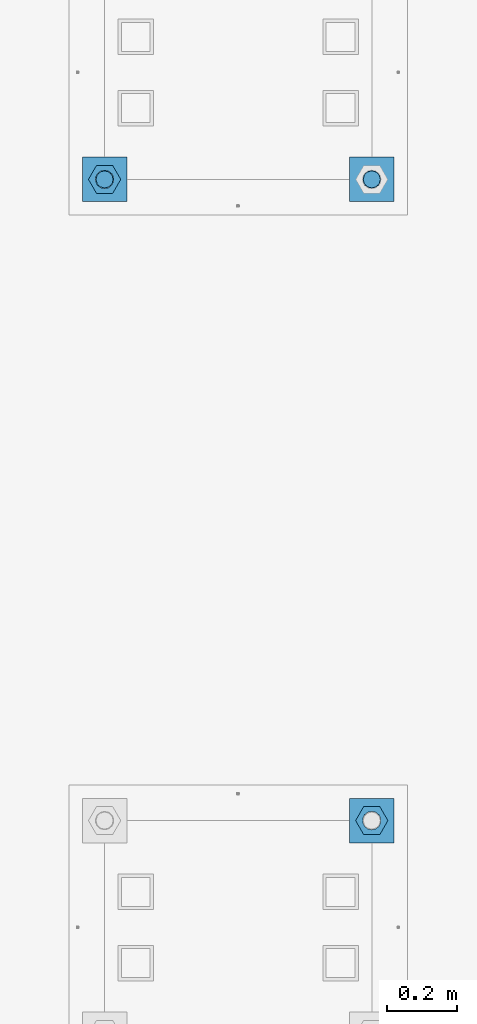
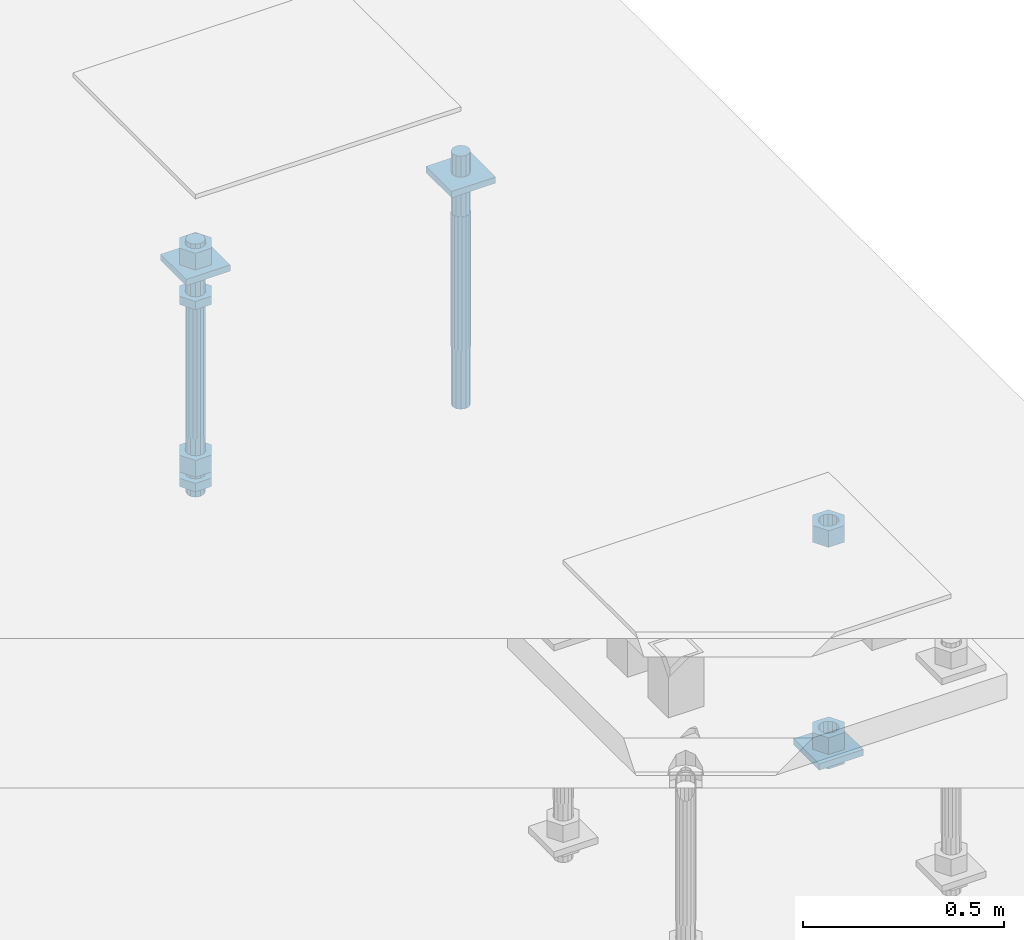
# One storey, part 2740 of 3843: 12 beams, 2 elements without a shape of their own.
"""IFC2X3 building model written with IfcOpenShell, lengths in millimetres."""

from ifc_helpers import new_model, si_unit, frame, origin_with_axes, place, context, subcontext, project, spatial, faceted_brep, material, type_object, element, aggregate, save


model = new_model("IFC2X3")

# Units and contexts
model_context = context("Model", 3, precision=1e-05, world=origin_with_axes())
body_context = subcontext(model_context, "Body", "Model", "MODEL_VIEW")
ifc_project = project(units=[si_unit("LENGTHUNIT", "METRE", prefix="MILLI"), si_unit("AREAUNIT", "SQUARE_METRE"), si_unit("VOLUMEUNIT", "CUBIC_METRE"), si_unit("MASSUNIT", "GRAM", prefix="KILO"), si_unit("TIMEUNIT", "SECOND"), si_unit("PLANEANGLEUNIT", "RADIAN"), si_unit("SOLIDANGLEUNIT", "STERADIAN"), si_unit("THERMODYNAMICTEMPERATUREUNIT", "DEGREE_CELSIUS"), si_unit("LUMINOUSINTENSITYUNIT", "LUMEN")], contexts=[model_context])

# Site, building, storey
site_placement = place(None, origin_with_axes())
site = spatial("IfcSite", under=ifc_project, at=site_placement, CompositionType="ELEMENT")
building_placement = place(site_placement, origin_with_axes())
building = spatial("IfcBuilding", under=site, at=building_placement, Name="Undefined", CompositionType="ELEMENT")
storey_placement = place(building_placement, origin_with_axes())
storey = spatial("IfcBuildingStorey", under=building, at=storey_placement, Name="Undefined", CompositionType="ELEMENT", Elevation=0.0)

# Assembly, beams
assembly_1_placement = place(storey_placement, origin_with_axes())
assembly_1 = element("IfcElementAssembly", 1, at=assembly_1_placement, inside=storey, Name="TEMPLATE", AssemblyPlace="NOTDEFINED", PredefinedType="RIGID_FRAME")
ifc_material_1 = material(Name="STEEL/A572-50")
beam_type_1 = type_object("IfcBeamType", PredefinedType="NOTDEFINED")
beam_1_placement = place(assembly_1_placement, frame((118465.6, 38188.9000015259, 29873.575), z_axis=(1.0, 0.0, 0.0), x_axis=(0.0, 1.0, 0.0)))
beam_1 = element("IfcBeam", 2, at=beam_1_placement, type_object=beam_type_1, material=ifc_material_1, Name="WASHER_PLATE", context=body_context, shape_type="Brep", body=[
    faceted_brep([(0.0, 9.52500000000146, -63.5), (0.0, 9.52500000000146, 63.5), (127.0, 9.52500000000146, 63.5), (127.0, 9.52500000000146, -63.5), (0.0, -9.52500000000146, 63.5), (127.0, -9.52500000000146, 63.5), (0.0, -9.52500000000146, -63.5), (127.0, -9.52500000000146, -63.5)], [[[0, 1, 2, 3]], [[1, 4, 5, 2]], [[4, 6, 7, 5]], [[6, 0, 3, 7]], [[5, 7, 3, 2]], [[6, 4, 1, 0]]]),
])
beam_2_placement = place(assembly_1_placement, frame((119227.6, 38188.9000015259, 29873.575), z_axis=(1.0, 0.0, 0.0), x_axis=(0.0, 1.0, 0.0)))
beam_2 = element("IfcBeam", 3, at=beam_2_placement, type_object=beam_type_1, material=ifc_material_1, Name="WASHER_PLATE", context=body_context, shape_type="Brep", body=[
    faceted_brep([(0.0, 9.52500000000146, -63.5), (0.0, 9.52500000000146, 63.5), (127.0, 9.52500000000146, 63.5), (127.0, 9.52500000000146, -63.5), (0.0, -9.52500000000146, 63.5), (127.0, -9.52500000000146, 63.5), (0.0, -9.52500000000146, -63.5), (127.0, -9.52500000000146, -63.5)], [[[0, 1, 2, 3]], [[1, 4, 5, 2]], [[4, 6, 7, 5]], [[6, 0, 3, 7]], [[5, 7, 3, 2]], [[6, 4, 1, 0]]]),
])

# Assembly, beam
assembly_2_placement = place(storey_placement, origin_with_axes())
assembly_2 = element("IfcElementAssembly", 4, at=assembly_2_placement, inside=storey, Name="TEMPLATE", AssemblyPlace="NOTDEFINED", PredefinedType="RIGID_FRAME")
beam_3_placement = place(assembly_2_placement, frame((119227.6, 36360.1000015259, 29244.925), z_axis=(1.0, 0.0, 0.0), x_axis=(0.0, 1.0, 0.0)))
beam_3 = element("IfcBeam", 5, at=beam_3_placement, type_object=beam_type_1, material=ifc_material_1, Name="WASHER_PLATE", context=body_context, shape_type="Brep", body=[
    faceted_brep([(0.0, 9.52500000000146, -63.5), (0.0, 9.52500000000146, 63.5), (127.0, 9.52500000000146, 63.5), (127.0, 9.52500000000146, -63.5), (0.0, -9.52500000000146, 63.5), (127.0, -9.52500000000146, 63.5), (0.0, -9.52500000000146, -63.5), (127.0, -9.52500000000146, -63.5)], [[[0, 1, 2, 3]], [[1, 4, 5, 2]], [[4, 6, 7, 5]], [[6, 0, 3, 7]], [[5, 7, 3, 2]], [[6, 4, 1, 0]]]),
])

# Beam
ifc_material_2 = material(Name="STEEL/A36")
beam_type_2 = type_object("IfcBeamType", Name="2_HALF_NUT", PredefinedType="NOTDEFINED")
beam_4_placement = place(assembly_1_placement, frame((118465.6, 38252.4000015259, 29787.85), z_axis=(0.0, 1.0, 0.0), x_axis=(0.0, 0.0, -1.0)))
beam_4 = element("IfcBeam", 6, at=beam_4_placement, type_object=beam_type_2, material=ifc_material_2, Name="NUT", ObjectType="2_HALF_NUT", context=body_context, shape_type="Brep", body=[
    faceted_brep([(0.0, -46.0369987487793, 0.0), (0.0, -23.0184993743896, -39.869213104248), (25.4000000000015, -23.0184993743896, -39.869213104248), (25.4000000000015, -46.0369987487793, 0.0), (0.0, 23.0184993743896, -39.869213104248), (25.4000000000015, 23.0184993743896, -39.869213104248), (0.0, 46.0369987487793, 0.0), (25.4000000000015, 46.0369987487793, 0.0), (0.0, 23.0184993743896, 39.869213104248), (25.4000000000015, 23.0184993743896, 39.869213104248), (0.0, -23.0184993743896, 39.869213104248), (25.4000000000015, -23.0184993743896, 39.869213104248), (0.0, 0.0, 26.1940002441406), (0.0, 11.3650617044477, 23.5999013092805), (25.4000000000015, 11.3650617044477, 23.5999013092805), (25.4000000000015, 0.0, 26.1940002441406), (0.0, 20.4791109456419, 16.3316083006721), (25.4000000000015, 20.4791109456419, 16.3316083006721), (0.0, 25.5370200498292, 5.82867859874386), (25.4000000000015, 25.5370200498292, 5.82867859874386), (0.0, 25.5370200498292, -5.82867859874386), (25.4000000000015, 25.5370200498292, -5.82867859874386), (0.0, 20.4791109456419, -16.3316083006721), (25.4000000000015, 20.4791109456419, -16.3316083006721), (0.0, 11.3650617044477, -23.5999013092805), (25.4000000000015, 11.3650617044477, -23.5999013092805), (0.0, 0.0, -26.1940002441406), (25.4000000000015, 0.0, -26.1940002441406), (0.0, -11.3650617044477, -23.5999013092805), (25.4000000000015, -11.3650617044477, -23.5999013092805), (0.0, -20.4791109456419, -16.3316083006721), (25.4000000000015, -20.4791109456419, -16.3316083006721), (0.0, -25.5370200498292, -5.82867859874386), (25.4000000000015, -25.5370200498292, -5.82867859874386), (0.0, -25.5370200498292, 5.82867859874386), (25.4000000000015, -25.5370200498292, 5.82867859874386), (0.0, -20.4791109456419, 16.3316083006721), (25.4000000000015, -20.4791109456419, 16.3316083006721), (0.0, -11.3650617044477, 23.5999013092805), (25.4000000000015, -11.3650617044477, 23.5999013092805)], [[[0, 1, 2, 3]], [[1, 4, 5, 2]], [[4, 6, 7, 5]], [[6, 8, 9, 7]], [[8, 10, 11, 9]], [[10, 0, 3, 11]], [[12, 13, 14, 15]], [[13, 16, 17, 14]], [[16, 18, 19, 17]], [[18, 20, 21, 19]], [[20, 22, 23, 21]], [[22, 24, 25, 23]], [[24, 26, 27, 25]], [[26, 28, 29, 27]], [[28, 30, 31, 29]], [[30, 32, 33, 31]], [[32, 34, 35, 33]], [[34, 36, 37, 35]], [[36, 38, 39, 37]], [[38, 12, 15, 39]], [[5, 7, 9, 11, 3, 2], [17, 19, 21, 23, 25, 27, 29, 31, 33, 35, 37, 39, 15, 14]], [[10, 8, 6, 4, 1, 0], [38, 36, 34, 32, 30, 28, 26, 24, 22, 20, 18, 16, 13, 12]]]),
])

beam_5_placement = place(assembly_1_placement, frame((118465.6, 38252.4000015259, 29235.4), z_axis=(0.0, 1.0, 0.0), x_axis=(0.0, 0.0, -1.0)))
beam_5 = element("IfcBeam", 7, at=beam_5_placement, type_object=beam_type_2, material=ifc_material_2, Name="NUT", ObjectType="2_HALF_NUT", context=body_context, shape_type="Brep", body=[
    faceted_brep([(0.0, -46.0369987487793, 0.0), (0.0, -23.0184993743896, -39.869213104248), (25.4000000000015, -23.0184993743896, -39.869213104248), (25.4000000000015, -46.0369987487793, 0.0), (0.0, 23.0184993743896, -39.869213104248), (25.4000000000015, 23.0184993743896, -39.869213104248), (0.0, 46.0369987487793, 0.0), (25.4000000000015, 46.0369987487793, 0.0), (0.0, 23.0184993743896, 39.869213104248), (25.4000000000015, 23.0184993743896, 39.869213104248), (0.0, -23.0184993743896, 39.869213104248), (25.4000000000015, -23.0184993743896, 39.869213104248), (0.0, 0.0, 26.1940002441406), (0.0, 11.3650617044477, 23.5999013092805), (25.4000000000015, 11.3650617044477, 23.5999013092805), (25.4000000000015, 0.0, 26.1940002441406), (0.0, 20.4791109456419, 16.3316083006721), (25.4000000000015, 20.4791109456419, 16.3316083006721), (0.0, 25.5370200498292, 5.82867859874386), (25.4000000000015, 25.5370200498292, 5.82867859874386), (0.0, 25.5370200498292, -5.82867859874386), (25.4000000000015, 25.5370200498292, -5.82867859874386), (0.0, 20.4791109456419, -16.3316083006721), (25.4000000000015, 20.4791109456419, -16.3316083006721), (0.0, 11.3650617044477, -23.5999013092805), (25.4000000000015, 11.3650617044477, -23.5999013092805), (0.0, 0.0, -26.1940002441406), (25.4000000000015, 0.0, -26.1940002441406), (0.0, -11.3650617044477, -23.5999013092805), (25.4000000000015, -11.3650617044477, -23.5999013092805), (0.0, -20.4791109456419, -16.3316083006721), (25.4000000000015, -20.4791109456419, -16.3316083006721), (0.0, -25.5370200498292, -5.82867859874386), (25.4000000000015, -25.5370200498292, -5.82867859874386), (0.0, -25.5370200498292, 5.82867859874386), (25.4000000000015, -25.5370200498292, 5.82867859874386), (0.0, -20.4791109456419, 16.3316083006721), (25.4000000000015, -20.4791109456419, 16.3316083006721), (0.0, -11.3650617044477, 23.5999013092805), (25.4000000000015, -11.3650617044477, 23.5999013092805)], [[[0, 1, 2, 3]], [[1, 4, 5, 2]], [[4, 6, 7, 5]], [[6, 8, 9, 7]], [[8, 10, 11, 9]], [[10, 0, 3, 11]], [[12, 13, 14, 15]], [[13, 16, 17, 14]], [[16, 18, 19, 17]], [[18, 20, 21, 19]], [[20, 22, 23, 21]], [[22, 24, 25, 23]], [[24, 26, 27, 25]], [[26, 28, 29, 27]], [[28, 30, 31, 29]], [[30, 32, 33, 31]], [[32, 34, 35, 33]], [[34, 36, 37, 35]], [[36, 38, 39, 37]], [[38, 12, 15, 39]], [[5, 7, 9, 11, 3, 2], [17, 19, 21, 23, 25, 27, 29, 31, 33, 35, 37, 39, 15, 14]], [[10, 8, 6, 4, 1, 0], [38, 36, 34, 32, 30, 28, 26, 24, 22, 20, 18, 16, 13, 12]]]),
])

beam_6_placement = place(assembly_2_placement, frame((119227.6, 36423.6000015259, 29235.4), z_axis=(0.0, 1.0, 0.0), x_axis=(0.0, 0.0, -1.0)))
beam_6 = element("IfcBeam", 8, at=beam_6_placement, type_object=beam_type_2, material=ifc_material_2, Name="NUT", ObjectType="2_HALF_NUT", context=body_context, shape_type="Brep", body=[
    faceted_brep([(0.0, -46.0369987487793, 0.0), (0.0, -23.0184993743896, -39.869213104248), (25.4000000000015, -23.0184993743896, -39.869213104248), (25.4000000000015, -46.0369987487793, 0.0), (0.0, 23.0184993743896, -39.869213104248), (25.4000000000015, 23.0184993743896, -39.869213104248), (0.0, 46.0369987487793, 0.0), (25.4000000000015, 46.0369987487793, 0.0), (0.0, 23.0184993743896, 39.869213104248), (25.4000000000015, 23.0184993743896, 39.869213104248), (0.0, -23.0184993743896, 39.869213104248), (25.4000000000015, -23.0184993743896, 39.869213104248), (0.0, 0.0, 26.1940002441406), (0.0, 11.3650617044477, 23.5999013092805), (25.4000000000015, 11.3650617044477, 23.5999013092805), (25.4000000000015, 0.0, 26.1940002441406), (0.0, 20.4791109456419, 16.3316083006721), (25.4000000000015, 20.4791109456419, 16.3316083006721), (0.0, 25.5370200498292, 5.82867859874386), (25.4000000000015, 25.5370200498292, 5.82867859874386), (0.0, 25.5370200498292, -5.82867859874386), (25.4000000000015, 25.5370200498292, -5.82867859874386), (0.0, 20.4791109456419, -16.3316083006721), (25.4000000000015, 20.4791109456419, -16.3316083006721), (0.0, 11.3650617044477, -23.5999013092805), (25.4000000000015, 11.3650617044477, -23.5999013092805), (0.0, 0.0, -26.1940002441406), (25.4000000000015, 0.0, -26.1940002441406), (0.0, -11.3650617044477, -23.5999013092805), (25.4000000000015, -11.3650617044477, -23.5999013092805), (0.0, -20.4791109456419, -16.3316083006721), (25.4000000000015, -20.4791109456419, -16.3316083006721), (0.0, -25.5370200498292, -5.82867859874386), (25.4000000000015, -25.5370200498292, -5.82867859874386), (0.0, -25.5370200498292, 5.82867859874386), (25.4000000000015, -25.5370200498292, 5.82867859874386), (0.0, -20.4791109456419, 16.3316083006721), (25.4000000000015, -20.4791109456419, 16.3316083006721), (0.0, -11.3650617044477, 23.5999013092805), (25.4000000000015, -11.3650617044477, 23.5999013092805)], [[[0, 1, 2, 3]], [[1, 4, 5, 2]], [[4, 6, 7, 5]], [[6, 8, 9, 7]], [[8, 10, 11, 9]], [[10, 0, 3, 11]], [[12, 13, 14, 15]], [[13, 16, 17, 14]], [[16, 18, 19, 17]], [[18, 20, 21, 19]], [[20, 22, 23, 21]], [[22, 24, 25, 23]], [[24, 26, 27, 25]], [[26, 28, 29, 27]], [[28, 30, 31, 29]], [[30, 32, 33, 31]], [[32, 34, 35, 33]], [[34, 36, 37, 35]], [[36, 38, 39, 37]], [[38, 12, 15, 39]], [[5, 7, 9, 11, 3, 2], [17, 19, 21, 23, 25, 27, 29, 31, 33, 35, 37, 39, 15, 14]], [[10, 8, 6, 4, 1, 0], [38, 36, 34, 32, 30, 28, 26, 24, 22, 20, 18, 16, 13, 12]]]),
])

beam_type_3 = type_object("IfcBeamType", Name="2_HEAVY_HEX_NUT", PredefinedType="NOTDEFINED")
beam_7_placement = place(assembly_1_placement, frame((118465.6, 38252.4000015259, 29933.9), z_axis=(0.0, 1.0, 0.0), x_axis=(0.0, 0.0, -1.0)))
beam_7 = element("IfcBeam", 9, at=beam_7_placement, type_object=beam_type_3, material=ifc_material_2, Name="NUT", ObjectType="2_HEAVY_HEX_NUT", context=body_context, shape_type="Brep", body=[
    faceted_brep([(0.0, -46.0369987487793, 0.0), (0.0, -23.0184993743896, -39.869213104248), (50.7999999999993, -23.0184993743896, -39.869213104248), (50.7999999999993, -46.0369987487793, 0.0), (0.0, 23.0184993743896, -39.869213104248), (50.7999999999993, 23.0184993743896, -39.869213104248), (0.0, 46.0369987487793, 0.0), (50.7999999999993, 46.0369987487793, 0.0), (0.0, 23.0184993743896, 39.869213104248), (50.7999999999993, 23.0184993743896, 39.869213104248), (0.0, -23.0184993743896, 39.869213104248), (50.7999999999993, -23.0184993743896, 39.869213104248), (0.0, 0.0, 26.1940002441406), (0.0, 11.3650617044477, 23.5999013092805), (50.7999999999993, 11.3650617044477, 23.5999013092805), (50.7999999999993, 0.0, 26.1940002441406), (0.0, 20.4791109456419, 16.3316083006721), (50.7999999999993, 20.4791109456419, 16.3316083006721), (0.0, 25.5370200498292, 5.82867859874386), (50.7999999999993, 25.5370200498292, 5.82867859874386), (0.0, 25.5370200498292, -5.82867859874386), (50.7999999999993, 25.5370200498292, -5.82867859874386), (0.0, 20.4791109456419, -16.3316083006721), (50.7999999999993, 20.4791109456419, -16.3316083006721), (0.0, 11.3650617044477, -23.5999013092805), (50.7999999999993, 11.3650617044477, -23.5999013092805), (0.0, 0.0, -26.1940002441406), (50.7999999999993, 0.0, -26.1940002441406), (0.0, -11.3650617044477, -23.5999013092805), (50.7999999999993, -11.3650617044477, -23.5999013092805), (0.0, -20.4791109456419, -16.3316083006721), (50.7999999999993, -20.4791109456419, -16.3316083006721), (0.0, -25.5370200498292, -5.82867859874386), (50.7999999999993, -25.5370200498292, -5.82867859874386), (0.0, -25.5370200498292, 5.82867859874386), (50.7999999999993, -25.5370200498292, 5.82867859874386), (0.0, -20.4791109456419, 16.3316083006721), (50.7999999999993, -20.4791109456419, 16.3316083006721), (0.0, -11.3650617044477, 23.5999013092805), (50.7999999999993, -11.3650617044477, 23.5999013092805)], [[[0, 1, 2, 3]], [[1, 4, 5, 2]], [[4, 6, 7, 5]], [[6, 8, 9, 7]], [[8, 10, 11, 9]], [[10, 0, 3, 11]], [[12, 13, 14, 15]], [[13, 16, 17, 14]], [[16, 18, 19, 17]], [[18, 20, 21, 19]], [[20, 22, 23, 21]], [[22, 24, 25, 23]], [[24, 26, 27, 25]], [[26, 28, 29, 27]], [[28, 30, 31, 29]], [[30, 32, 33, 31]], [[32, 34, 35, 33]], [[34, 36, 37, 35]], [[36, 38, 39, 37]], [[38, 12, 15, 39]], [[5, 7, 9, 11, 3, 2], [17, 19, 21, 23, 25, 27, 29, 31, 33, 35, 37, 39, 15, 14]], [[10, 8, 6, 4, 1, 0], [38, 36, 34, 32, 30, 28, 26, 24, 22, 20, 18, 16, 13, 12]]]),
])

beam_8_placement = place(assembly_1_placement, frame((118465.6, 38252.4000015259, 29305.25), z_axis=(0.0, 1.0, 0.0), x_axis=(0.0, 0.0, -1.0)))
beam_8 = element("IfcBeam", 10, at=beam_8_placement, type_object=beam_type_3, material=ifc_material_2, Name="NUT", ObjectType="2_HEAVY_HEX_NUT", context=body_context, shape_type="Brep", body=[
    faceted_brep([(0.0, -46.0369987487793, 0.0), (0.0, -23.0184993743896, -39.869213104248), (50.7999999999993, -23.0184993743896, -39.869213104248), (50.7999999999993, -46.0369987487793, 0.0), (0.0, 23.0184993743896, -39.869213104248), (50.7999999999993, 23.0184993743896, -39.869213104248), (0.0, 46.0369987487793, 0.0), (50.7999999999993, 46.0369987487793, 0.0), (0.0, 23.0184993743896, 39.869213104248), (50.7999999999993, 23.0184993743896, 39.869213104248), (0.0, -23.0184993743896, 39.869213104248), (50.7999999999993, -23.0184993743896, 39.869213104248), (0.0, 0.0, 26.1940002441406), (0.0, 11.3650617044477, 23.5999013092805), (50.7999999999993, 11.3650617044477, 23.5999013092805), (50.7999999999993, 0.0, 26.1940002441406), (0.0, 20.4791109456419, 16.3316083006721), (50.7999999999993, 20.4791109456419, 16.3316083006721), (0.0, 25.5370200498292, 5.82867859874386), (50.7999999999993, 25.5370200498292, 5.82867859874386), (0.0, 25.5370200498292, -5.82867859874386), (50.7999999999993, 25.5370200498292, -5.82867859874386), (0.0, 20.4791109456419, -16.3316083006721), (50.7999999999993, 20.4791109456419, -16.3316083006721), (0.0, 11.3650617044477, -23.5999013092805), (50.7999999999993, 11.3650617044477, -23.5999013092805), (0.0, 0.0, -26.1940002441406), (50.7999999999993, 0.0, -26.1940002441406), (0.0, -11.3650617044477, -23.5999013092805), (50.7999999999993, -11.3650617044477, -23.5999013092805), (0.0, -20.4791109456419, -16.3316083006721), (50.7999999999993, -20.4791109456419, -16.3316083006721), (0.0, -25.5370200498292, -5.82867859874386), (50.7999999999993, -25.5370200498292, -5.82867859874386), (0.0, -25.5370200498292, 5.82867859874386), (50.7999999999993, -25.5370200498292, 5.82867859874386), (0.0, -20.4791109456419, 16.3316083006721), (50.7999999999993, -20.4791109456419, 16.3316083006721), (0.0, -11.3650617044477, 23.5999013092805), (50.7999999999993, -11.3650617044477, 23.5999013092805)], [[[0, 1, 2, 3]], [[1, 4, 5, 2]], [[4, 6, 7, 5]], [[6, 8, 9, 7]], [[8, 10, 11, 9]], [[10, 0, 3, 11]], [[12, 13, 14, 15]], [[13, 16, 17, 14]], [[16, 18, 19, 17]], [[18, 20, 21, 19]], [[20, 22, 23, 21]], [[22, 24, 25, 23]], [[24, 26, 27, 25]], [[26, 28, 29, 27]], [[28, 30, 31, 29]], [[30, 32, 33, 31]], [[32, 34, 35, 33]], [[34, 36, 37, 35]], [[36, 38, 39, 37]], [[38, 12, 15, 39]], [[5, 7, 9, 11, 3, 2], [17, 19, 21, 23, 25, 27, 29, 31, 33, 35, 37, 39, 15, 14]], [[10, 8, 6, 4, 1, 0], [38, 36, 34, 32, 30, 28, 26, 24, 22, 20, 18, 16, 13, 12]]]),
])

beam_9_placement = place(assembly_2_placement, frame((119227.6, 36423.6000015259, 29933.9), z_axis=(0.0, 1.0, 0.0), x_axis=(0.0, 0.0, -1.0)))
beam_9 = element("IfcBeam", 11, at=beam_9_placement, type_object=beam_type_3, material=ifc_material_2, Name="NUT", ObjectType="2_HEAVY_HEX_NUT", context=body_context, shape_type="Brep", body=[
    faceted_brep([(0.0, -46.0369987487793, 0.0), (0.0, -23.0184993743896, -39.869213104248), (50.7999999999993, -23.0184993743896, -39.869213104248), (50.7999999999993, -46.0369987487793, 0.0), (0.0, 23.0184993743896, -39.869213104248), (50.7999999999993, 23.0184993743896, -39.869213104248), (0.0, 46.0369987487793, 0.0), (50.7999999999993, 46.0369987487793, 0.0), (0.0, 23.0184993743896, 39.869213104248), (50.7999999999993, 23.0184993743896, 39.869213104248), (0.0, -23.0184993743896, 39.869213104248), (50.7999999999993, -23.0184993743896, 39.869213104248), (0.0, 0.0, 26.1940002441406), (0.0, 11.3650617044477, 23.5999013092805), (50.7999999999993, 11.3650617044477, 23.5999013092805), (50.7999999999993, 0.0, 26.1940002441406), (0.0, 20.4791109456419, 16.3316083006721), (50.7999999999993, 20.4791109456419, 16.3316083006721), (0.0, 25.5370200498292, 5.82867859874386), (50.7999999999993, 25.5370200498292, 5.82867859874386), (0.0, 25.5370200498292, -5.82867859874386), (50.7999999999993, 25.5370200498292, -5.82867859874386), (0.0, 20.4791109456419, -16.3316083006721), (50.7999999999993, 20.4791109456419, -16.3316083006721), (0.0, 11.3650617044477, -23.5999013092805), (50.7999999999993, 11.3650617044477, -23.5999013092805), (0.0, 0.0, -26.1940002441406), (50.7999999999993, 0.0, -26.1940002441406), (0.0, -11.3650617044477, -23.5999013092805), (50.7999999999993, -11.3650617044477, -23.5999013092805), (0.0, -20.4791109456419, -16.3316083006721), (50.7999999999993, -20.4791109456419, -16.3316083006721), (0.0, -25.5370200498292, -5.82867859874386), (50.7999999999993, -25.5370200498292, -5.82867859874386), (0.0, -25.5370200498292, 5.82867859874386), (50.7999999999993, -25.5370200498292, 5.82867859874386), (0.0, -20.4791109456419, 16.3316083006721), (50.7999999999993, -20.4791109456419, 16.3316083006721), (0.0, -11.3650617044477, 23.5999013092805), (50.7999999999993, -11.3650617044477, 23.5999013092805)], [[[0, 1, 2, 3]], [[1, 4, 5, 2]], [[4, 6, 7, 5]], [[6, 8, 9, 7]], [[8, 10, 11, 9]], [[10, 0, 3, 11]], [[12, 13, 14, 15]], [[13, 16, 17, 14]], [[16, 18, 19, 17]], [[18, 20, 21, 19]], [[20, 22, 23, 21]], [[22, 24, 25, 23]], [[24, 26, 27, 25]], [[26, 28, 29, 27]], [[28, 30, 31, 29]], [[30, 32, 33, 31]], [[32, 34, 35, 33]], [[34, 36, 37, 35]], [[36, 38, 39, 37]], [[38, 12, 15, 39]], [[5, 7, 9, 11, 3, 2], [17, 19, 21, 23, 25, 27, 29, 31, 33, 35, 37, 39, 15, 14]], [[10, 8, 6, 4, 1, 0], [38, 36, 34, 32, 30, 28, 26, 24, 22, 20, 18, 16, 13, 12]]]),
])

beam_10_placement = place(assembly_2_placement, frame((119227.6, 36423.6000015259, 29305.25), z_axis=(0.0, 1.0, 0.0), x_axis=(0.0, 0.0, -1.0)))
beam_10 = element("IfcBeam", 12, at=beam_10_placement, type_object=beam_type_3, material=ifc_material_2, Name="NUT", ObjectType="2_HEAVY_HEX_NUT", context=body_context, shape_type="Brep", body=[
    faceted_brep([(0.0, -46.0369987487793, 0.0), (0.0, -23.0184993743896, -39.869213104248), (50.7999999999993, -23.0184993743896, -39.869213104248), (50.7999999999993, -46.0369987487793, 0.0), (0.0, 23.0184993743896, -39.869213104248), (50.7999999999993, 23.0184993743896, -39.869213104248), (0.0, 46.0369987487793, 0.0), (50.7999999999993, 46.0369987487793, 0.0), (0.0, 23.0184993743896, 39.869213104248), (50.7999999999993, 23.0184993743896, 39.869213104248), (0.0, -23.0184993743896, 39.869213104248), (50.7999999999993, -23.0184993743896, 39.869213104248), (0.0, 0.0, 26.1940002441406), (0.0, 11.3650617044477, 23.5999013092805), (50.7999999999993, 11.3650617044477, 23.5999013092805), (50.7999999999993, 0.0, 26.1940002441406), (0.0, 20.4791109456419, 16.3316083006721), (50.7999999999993, 20.4791109456419, 16.3316083006721), (0.0, 25.5370200498292, 5.82867859874386), (50.7999999999993, 25.5370200498292, 5.82867859874386), (0.0, 25.5370200498292, -5.82867859874386), (50.7999999999993, 25.5370200498292, -5.82867859874386), (0.0, 20.4791109456419, -16.3316083006721), (50.7999999999993, 20.4791109456419, -16.3316083006721), (0.0, 11.3650617044477, -23.5999013092805), (50.7999999999993, 11.3650617044477, -23.5999013092805), (0.0, 0.0, -26.1940002441406), (50.7999999999993, 0.0, -26.1940002441406), (0.0, -11.3650617044477, -23.5999013092805), (50.7999999999993, -11.3650617044477, -23.5999013092805), (0.0, -20.4791109456419, -16.3316083006721), (50.7999999999993, -20.4791109456419, -16.3316083006721), (0.0, -25.5370200498292, -5.82867859874386), (50.7999999999993, -25.5370200498292, -5.82867859874386), (0.0, -25.5370200498292, 5.82867859874386), (50.7999999999993, -25.5370200498292, 5.82867859874386), (0.0, -20.4791109456419, 16.3316083006721), (50.7999999999993, -20.4791109456419, 16.3316083006721), (0.0, -11.3650617044477, 23.5999013092805), (50.7999999999993, -11.3650617044477, 23.5999013092805)], [[[0, 1, 2, 3]], [[1, 4, 5, 2]], [[4, 6, 7, 5]], [[6, 8, 9, 7]], [[8, 10, 11, 9]], [[10, 0, 3, 11]], [[12, 13, 14, 15]], [[13, 16, 17, 14]], [[16, 18, 19, 17]], [[18, 20, 21, 19]], [[20, 22, 23, 21]], [[22, 24, 25, 23]], [[24, 26, 27, 25]], [[26, 28, 29, 27]], [[28, 30, 31, 29]], [[30, 32, 33, 31]], [[32, 34, 35, 33]], [[34, 36, 37, 35]], [[36, 38, 39, 37]], [[38, 12, 15, 39]], [[5, 7, 9, 11, 3, 2], [17, 19, 21, 23, 25, 27, 29, 31, 33, 35, 37, 39, 15, 14]], [[10, 8, 6, 4, 1, 0], [38, 36, 34, 32, 30, 28, 26, 24, 22, 20, 18, 16, 13, 12]]]),
])

aggregate(assembly_2, [beam_9, beam_10, beam_6, beam_3])

ifc_material_3 = material()
beam_type_4 = type_object("IfcBeamType", PredefinedType="NOTDEFINED")
beam_11_placement = place(assembly_1_placement, frame((118465.600001526, 38252.4, 29762.45), z_axis=(1.0, 0.0, 0.0), x_axis=(0.0, 0.0, -1.0)))
beam_11 = element("IfcBeam", 13, at=beam_11_placement, type_object=beam_type_4, material=ifc_material_3, Name="ANCHOR_ROD", context=body_context, shape_type="Brep", body=[
    faceted_brep([(0.0, -23.4665401257807, -9.72015918207035), (0.0, -17.9605122421344, -17.9605122421417), (406.399999999998, -17.9605122421344, -17.9605122421417), (406.399999999998, -23.4665401257807, -9.72015918207035), (0.0, -9.72015918207762, -23.466540125788), (406.399999999998, -9.72015918207762, -23.466540125788), (0.0, 0.0, -25.4000000000015), (406.399999999998, 0.0, -25.4000000000015), (0.0, 9.72015918207762, -23.466540125788), (406.399999999998, 9.72015918207762, -23.466540125788), (0.0, 17.9605122421344, -17.9605122421417), (406.399999999998, 17.9605122421344, -17.9605122421417), (0.0, 23.4665401257807, -9.72015918207035), (406.399999999998, 23.4665401257807, -9.72015918207035), (0.0, 25.3999996185303, 0.0), (406.399999999998, 25.3999999999942, 0.0), (0.0, 23.4665401257807, 9.72015918207035), (406.399999999998, 23.4665401257807, 9.72015918207035), (0.0, 17.9605122421344, 17.9605122421417), (406.399999999998, 17.9605122421344, 17.9605122421417), (0.0, 9.72015918207762, 23.466540125788), (406.399999999998, 9.72015918207762, 23.466540125788), (0.0, 0.0, 25.4000000000015), (406.399999999998, 0.0, 25.4000000000015), (0.0, -9.72015918207762, 23.466540125788), (406.399999999998, -9.72015918207762, 23.466540125788), (0.0, -17.9605122421344, 17.9605122421417), (406.399999999998, -17.9605122421344, 17.9605122421417), (0.0, -23.4665401257807, 9.72015918207035), (406.399999999998, -23.4665401257807, 9.72015918207035), (0.0, -25.3999996185303, 0.0), (406.399999999998, -25.3999999999942, 0.0), (584.200000000001, -12.2499999999854, -21.2176223927163), (584.200000000001, 1.45519152283669e-11, -24.5), (584.200000000001, 12.2500000000146, -21.2176223927163), (584.200000000001, 21.2176223927381, -12.25), (584.200000000001, 24.5000000000146, 0.0), (584.200000000001, 21.2176223927381, 12.25), (584.200000000001, 12.2500000000146, 21.2176223927163), (584.200000000001, 1.45519152283669e-11, 24.5), (584.200000000001, -12.2499999999854, 21.2176223927163), (584.200000000001, -21.217622392709, 12.25), (584.200000000001, -24.4999999999854, 0.0), (584.200000000001, -21.217622392709, -12.25), (406.399999999998, -24.4999999999854, 0.0), (406.399999999998, -21.217622392709, -12.25), (406.399999999998, -12.2499999999854, -21.2176223927163), (406.399999999998, 1.45519152283669e-11, -24.5), (406.399999999998, 12.2500000000146, -21.2176223927163), (406.399999999998, 21.2176223927381, -12.25), (406.399999999998, 24.5000000000146, 0.0), (406.399999999998, 21.2176223927381, 12.25), (406.399999999998, 12.2500000000146, 21.2176223927163), (406.399999999998, 1.45519152283669e-11, 24.5), (406.399999999998, -12.2499999999854, 21.2176223927163), (406.399999999998, -21.217622392709, 12.25), (0.0, 12.2500000000146, 21.2176223927163), (0.0, 1.45519152283669e-11, 24.5), (0.0, -12.2499999999854, 21.2176223927163), (0.0, -21.217622392709, 12.25), (0.0, -24.4999999999854, 0.0), (0.0, -21.217622392709, -12.25), (0.0, -12.2499999999854, -21.2176223927163), (0.0, 1.45519152283669e-11, -24.5), (0.0, 12.2500000000146, -21.2176223927163), (0.0, 21.2176223927381, -12.25), (0.0, 24.5000000000146, 0.0), (0.0, 21.2176223927381, 12.25), (-184.150000000001, -21.217622392709, 12.25), (-184.150000000001, -12.2499999999854, 21.2176223927163), (-184.150000000001, 1.45519152283669e-11, 24.5), (-184.150000000001, 12.2500000000146, 21.2176223927163), (-184.150000000001, 21.2176223927381, 12.25), (-184.150000000001, 24.5000000000146, 0.0), (-184.150000000001, 21.2176223927381, -12.25), (-184.150000000001, 12.2500000000146, -21.2176223927163), (-184.150000000001, 1.45519152283669e-11, -24.5), (-184.150000000001, -12.2499999999854, -21.2176223927163), (-184.150000000001, -21.217622392709, -12.25), (-184.150000000001, -24.4999999999854, 0.0)], [[[0, 1, 2, 3]], [[1, 4, 5, 2]], [[4, 6, 7, 5]], [[6, 8, 9, 7]], [[8, 10, 11, 9]], [[10, 12, 13, 11]], [[12, 14, 15, 13]], [[14, 16, 17, 15]], [[16, 18, 19, 17]], [[18, 20, 21, 19]], [[20, 22, 23, 21]], [[22, 24, 25, 23]], [[24, 26, 27, 25]], [[26, 28, 29, 27]], [[28, 30, 31, 29]], [[32, 33, 34, 35, 36, 37, 38, 39, 40, 41, 42, 43]], [[43, 42, 44, 45]], [[32, 43, 45, 46]], [[33, 32, 46, 47]], [[34, 33, 47, 48]], [[35, 34, 48, 49]], [[36, 35, 49, 50]], [[37, 36, 50, 51]], [[38, 37, 51, 52]], [[39, 38, 52, 53]], [[40, 39, 53, 54]], [[41, 40, 54, 55]], [[42, 41, 55, 44]], [[2, 5, 7, 9, 11, 13, 15, 17, 19, 21, 23, 25, 27, 29, 31, 3], [54, 53, 52, 51, 50, 49, 48, 47, 46, 45, 44, 55]], [[30, 0, 3, 31]], [[28, 26, 24, 22, 20, 18, 16, 14, 12, 10, 8, 6, 4, 1, 0, 30], [56, 57, 58, 59, 60, 61, 62, 63, 64, 65, 66, 67]], [[68, 69, 70, 71, 72, 73, 74, 75, 76, 77, 78, 79]], [[71, 70, 57, 56]], [[72, 71, 56, 67]], [[73, 72, 67, 66]], [[74, 73, 66, 65]], [[75, 74, 65, 64]], [[76, 75, 64, 63]], [[77, 76, 63, 62]], [[78, 77, 62, 61]], [[79, 78, 61, 60]], [[68, 79, 60, 59]], [[69, 68, 59, 58]], [[70, 69, 58, 57]]]),
])

beam_12_placement = place(assembly_1_placement, frame((119227.600001526, 38252.4, 29762.45), z_axis=(1.0, 0.0, 0.0), x_axis=(0.0, 0.0, -1.0)))
beam_12 = element("IfcBeam", 14, at=beam_12_placement, type_object=beam_type_4, material=ifc_material_3, Name="ANCHOR_ROD", context=body_context, shape_type="Brep", body=[
    faceted_brep([(0.0, -23.4665401257807, -9.72015918207035), (0.0, -17.9605122421344, -17.9605122421417), (406.399999999998, -17.9605122421344, -17.9605122421417), (406.399999999998, -23.4665401257807, -9.72015918207035), (0.0, -9.72015918207762, -23.466540125788), (406.399999999998, -9.72015918207762, -23.466540125788), (0.0, 0.0, -25.4000000000015), (406.399999999998, 0.0, -25.4000000000015), (0.0, 9.72015918207762, -23.466540125788), (406.399999999998, 9.72015918207762, -23.466540125788), (0.0, 17.9605122421344, -17.9605122421417), (406.399999999998, 17.9605122421344, -17.9605122421417), (0.0, 23.4665401257807, -9.72015918207035), (406.399999999998, 23.4665401257807, -9.72015918207035), (0.0, 25.3999996185303, 0.0), (406.399999999998, 25.3999999999942, 0.0), (0.0, 23.4665401257807, 9.72015918207035), (406.399999999998, 23.4665401257807, 9.72015918207035), (0.0, 17.9605122421344, 17.9605122421417), (406.399999999998, 17.9605122421344, 17.9605122421417), (0.0, 9.72015918207762, 23.466540125788), (406.399999999998, 9.72015918207762, 23.466540125788), (0.0, 0.0, 25.4000000000015), (406.399999999998, 0.0, 25.4000000000015), (0.0, -9.72015918207762, 23.466540125788), (406.399999999998, -9.72015918207762, 23.466540125788), (0.0, -17.9605122421344, 17.9605122421417), (406.399999999998, -17.9605122421344, 17.9605122421417), (0.0, -23.4665401257807, 9.72015918207035), (406.399999999998, -23.4665401257807, 9.72015918207035), (0.0, -25.3999996185303, 0.0), (406.399999999998, -25.3999999999942, 0.0), (584.200000000001, -12.2499999999854, -21.2176223927163), (584.200000000001, 1.45519152283669e-11, -24.5), (584.200000000001, 12.2500000000146, -21.2176223927163), (584.200000000001, 21.2176223927381, -12.25), (584.200000000001, 24.5000000000146, 0.0), (584.200000000001, 21.2176223927381, 12.25), (584.200000000001, 12.2500000000146, 21.2176223927163), (584.200000000001, 1.45519152283669e-11, 24.5), (584.200000000001, -12.2499999999854, 21.2176223927163), (584.200000000001, -21.217622392709, 12.25), (584.200000000001, -24.4999999999854, 0.0), (584.200000000001, -21.217622392709, -12.25), (406.399999999998, -24.4999999999854, 0.0), (406.399999999998, -21.217622392709, -12.25), (406.399999999998, -12.2499999999854, -21.2176223927163), (406.399999999998, 1.45519152283669e-11, -24.5), (406.399999999998, 12.2500000000146, -21.2176223927163), (406.399999999998, 21.2176223927381, -12.25), (406.399999999998, 24.5000000000146, 0.0), (406.399999999998, 21.2176223927381, 12.25), (406.399999999998, 12.2500000000146, 21.2176223927163), (406.399999999998, 1.45519152283669e-11, 24.5), (406.399999999998, -12.2499999999854, 21.2176223927163), (406.399999999998, -21.217622392709, 12.25), (0.0, 12.2500000000146, 21.2176223927163), (0.0, 1.45519152283669e-11, 24.5), (0.0, -12.2499999999854, 21.2176223927163), (0.0, -21.217622392709, 12.25), (0.0, -24.4999999999854, 0.0), (0.0, -21.217622392709, -12.25), (0.0, -12.2499999999854, -21.2176223927163), (0.0, 1.45519152283669e-11, -24.5), (0.0, 12.2500000000146, -21.2176223927163), (0.0, 21.2176223927381, -12.25), (0.0, 24.5000000000146, 0.0), (0.0, 21.2176223927381, 12.25), (-184.150000000001, -21.217622392709, 12.25), (-184.150000000001, -12.2499999999854, 21.2176223927163), (-184.150000000001, 1.45519152283669e-11, 24.5), (-184.150000000001, 12.2500000000146, 21.2176223927163), (-184.150000000001, 21.2176223927381, 12.25), (-184.150000000001, 24.5000000000146, 0.0), (-184.150000000001, 21.2176223927381, -12.25), (-184.150000000001, 12.2500000000146, -21.2176223927163), (-184.150000000001, 1.45519152283669e-11, -24.5), (-184.150000000001, -12.2499999999854, -21.2176223927163), (-184.150000000001, -21.217622392709, -12.25), (-184.150000000001, -24.4999999999854, 0.0)], [[[0, 1, 2, 3]], [[1, 4, 5, 2]], [[4, 6, 7, 5]], [[6, 8, 9, 7]], [[8, 10, 11, 9]], [[10, 12, 13, 11]], [[12, 14, 15, 13]], [[14, 16, 17, 15]], [[16, 18, 19, 17]], [[18, 20, 21, 19]], [[20, 22, 23, 21]], [[22, 24, 25, 23]], [[24, 26, 27, 25]], [[26, 28, 29, 27]], [[28, 30, 31, 29]], [[32, 33, 34, 35, 36, 37, 38, 39, 40, 41, 42, 43]], [[43, 42, 44, 45]], [[32, 43, 45, 46]], [[33, 32, 46, 47]], [[34, 33, 47, 48]], [[35, 34, 48, 49]], [[36, 35, 49, 50]], [[37, 36, 50, 51]], [[38, 37, 51, 52]], [[39, 38, 52, 53]], [[40, 39, 53, 54]], [[41, 40, 54, 55]], [[42, 41, 55, 44]], [[2, 5, 7, 9, 11, 13, 15, 17, 19, 21, 23, 25, 27, 29, 31, 3], [54, 53, 52, 51, 50, 49, 48, 47, 46, 45, 44, 55]], [[30, 0, 3, 31]], [[28, 26, 24, 22, 20, 18, 16, 14, 12, 10, 8, 6, 4, 1, 0, 30], [56, 57, 58, 59, 60, 61, 62, 63, 64, 65, 66, 67]], [[68, 69, 70, 71, 72, 73, 74, 75, 76, 77, 78, 79]], [[71, 70, 57, 56]], [[72, 71, 56, 67]], [[73, 72, 67, 66]], [[74, 73, 66, 65]], [[75, 74, 65, 64]], [[76, 75, 64, 63]], [[77, 76, 63, 62]], [[78, 77, 62, 61]], [[79, 78, 61, 60]], [[68, 79, 60, 59]], [[69, 68, 59, 58]], [[70, 69, 58, 57]]]),
])

aggregate(assembly_1, [beam_11, beam_12, beam_1, beam_2, beam_4, beam_7, beam_8, beam_5])

save(model, "model.ifc")
